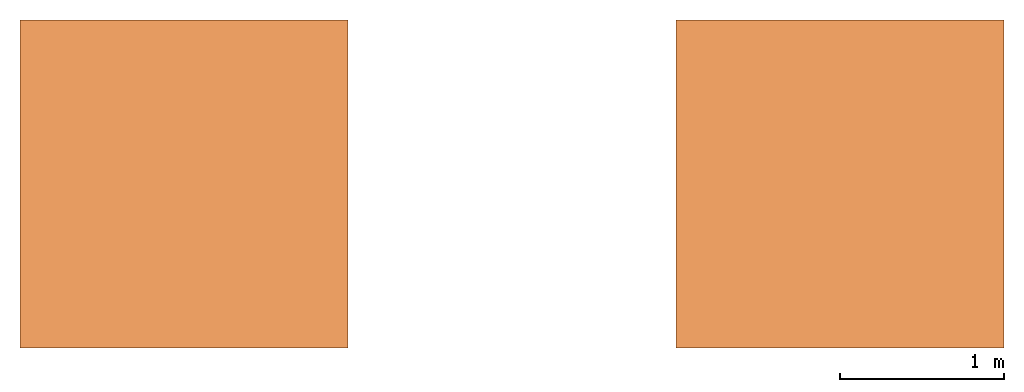
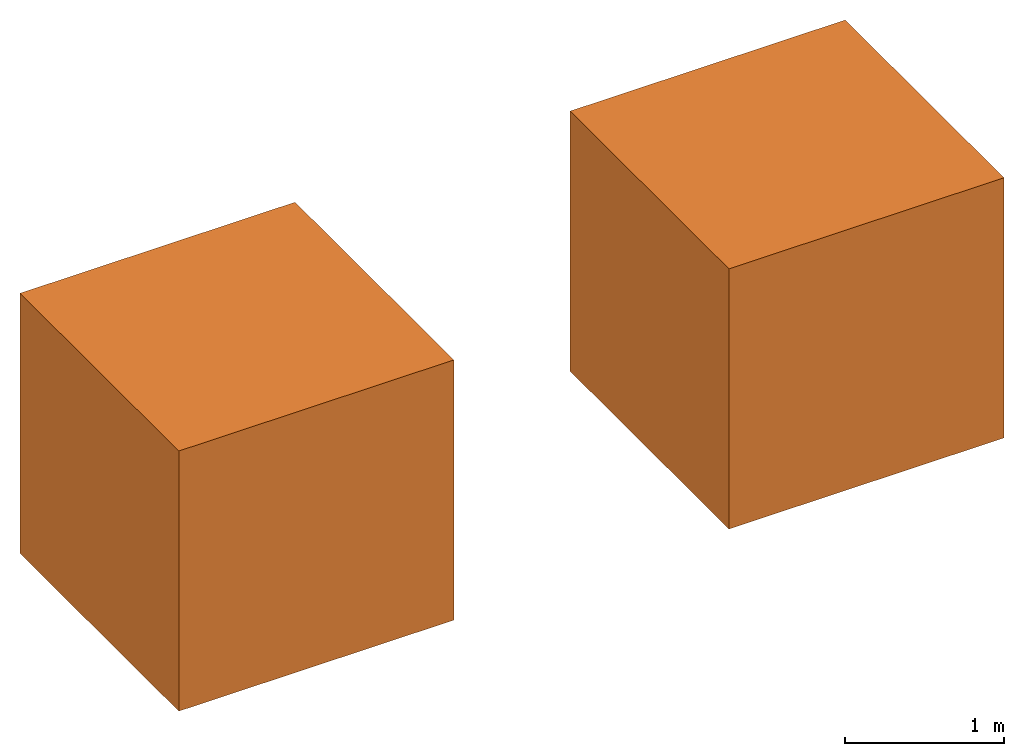
# One storey: 2 proxies.
"""IFC4 building model written with IfcOpenShell, lengths in metres."""

from ifc_helpers import new_model, si_unit, frame, origin_with_axes, place, context, subcontext, project, spatial, faceted_brep, source, transform, mapped, material, element, save


model = new_model("IFC4")

# Units and contexts
model_context = context("Model", 3, precision=1e-05, world=origin_with_axes())
plan_context = context("Plan", 2, precision=1e-05, world=origin_with_axes())
body_context = subcontext(model_context, "Body", "Model", "MODEL_VIEW")
ifc_project = project(units=[si_unit("LENGTHUNIT", "METRE"), si_unit("AREAUNIT", "SQUARE_METRE"), si_unit("VOLUMEUNIT", "CUBIC_METRE")], contexts=[model_context, plan_context])

# Site, building, storey
site_placement = place(None, origin_with_axes())
site = spatial("IfcSite", under=ifc_project, at=site_placement)
building_placement = place(site_placement, origin_with_axes())
building = spatial("IfcBuilding", under=site, at=building_placement, Name="Building")
storey_placement = place(building_placement, origin_with_axes())
storey = spatial("IfcBuildingStorey", under=building, at=storey_placement, Name="Ground Floor")

# Proxies
ifc_material = material(Name="Material")
shared_shape_1 = source(origin_with_axes(), body_context, "Body", "Brep", [
    faceted_brep([(1.0, 1.0, 1.0), (-1.0, 1.0, 1.0), (-1.0, -1.0, 1.0), (1.0, -1.0, 1.0), (1.0, -1.0, -1.0), (-1.0, -1.0, -1.0), (-1.0, 1.0, -1.0), (1.0, 1.0, -1.0)], [[[0, 1, 2, 3]], [[4, 3, 2, 5]], [[5, 2, 1, 6]], [[6, 7, 4, 5]], [[7, 0, 3, 4]], [[6, 1, 0, 7]]]),
])
proxy_1_placement = place(storey_placement, origin_with_axes())
element("IfcBuildingElementProxy", 1, at=proxy_1_placement, inside=storey, material=ifc_material, Name="Both", PredefinedType="NOTDEFINED", context=body_context, shape_type="MappedRepresentation", body=[
    mapped(shared_shape_1, transform((0.0, 0.0, 0.0), x_axis=(1.0, 0.0, 0.0), y_axis=(0.0, 1.0, 0.0), z_axis=(0.0, 0.0, 1.0), scale=1.0)),
])
shared_shape_2 = source(origin_with_axes(), body_context, "Body", "Brep", [
    faceted_brep([(1.0, 1.0, 1.0), (-1.0, 1.0, 1.0), (-1.0, -1.0, 1.0), (1.0, -1.0, 1.0), (1.0, -1.0, -1.0), (-1.0, -1.0, -1.0), (-1.0, 1.0, -1.0), (1.0, 1.0, -1.0)], [[[0, 1, 2, 3]], [[4, 3, 2, 5]], [[5, 2, 1, 6]], [[6, 7, 4, 5]], [[7, 0, 3, 4]], [[6, 1, 0, 7]]]),
])
proxy_2_placement = place(storey_placement, frame((4.0, 0.0, 0.0), z_axis=(0.0, 0.0, 1.0), x_axis=(1.0, 0.0, 0.0)))
element("IfcBuildingElementProxy", 2, at=proxy_2_placement, inside=storey, material=ifc_material, Name="Model", PredefinedType="NOTDEFINED", context=body_context, shape_type="MappedRepresentation", body=[
    mapped(shared_shape_2, transform((0.0, 0.0, 0.0), x_axis=(1.0, 0.0, 0.0), y_axis=(0.0, 1.0, 0.0), z_axis=(0.0, 0.0, 1.0), scale=1.0)),
])

save(model, "model.ifc")
